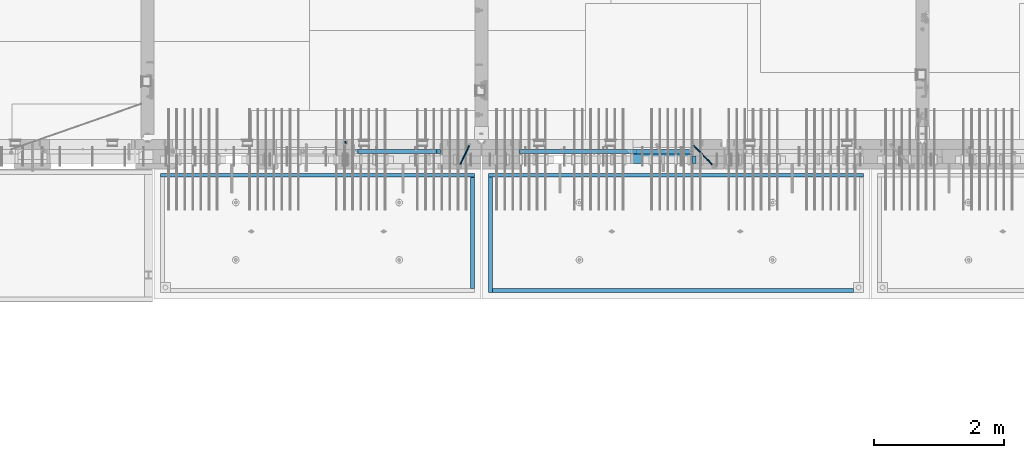
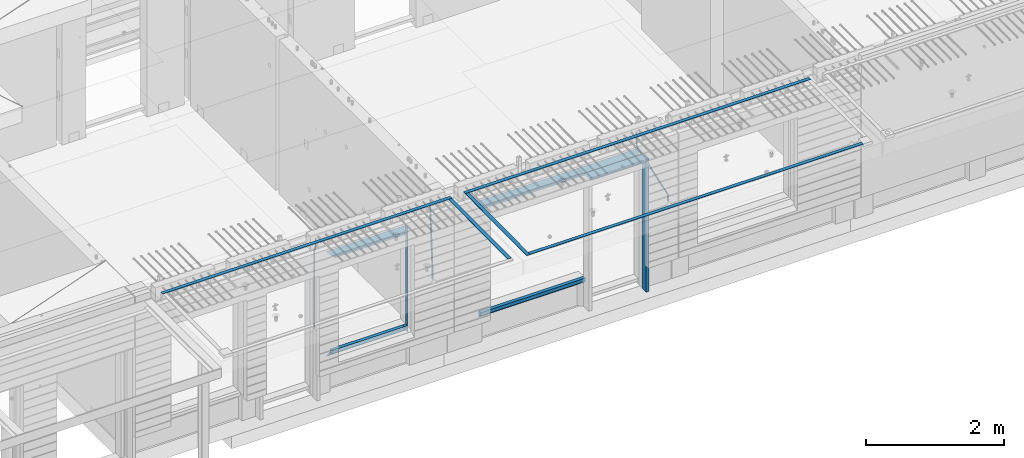
# One storey, part 87 of 325: 21 beams, 4 elements without a shape of their own.
"""IFC2X3 building model written with IfcOpenShell, lengths in millimetres."""

from ifc_helpers import new_model, si_unit, frame, origin_with_axes, place, context, subcontext, project, spatial, faceted_brep, material, type_object, element, aggregate, save


model = new_model("IFC2X3")

# Units and contexts
model_context = context("Model", 3, precision=1e-05, world=origin_with_axes())
body_context = subcontext(model_context, "Body", "Model", "MODEL_VIEW")
ifc_project = project(units=[si_unit("LENGTHUNIT", "METRE", prefix="MILLI"), si_unit("AREAUNIT", "SQUARE_METRE"), si_unit("VOLUMEUNIT", "CUBIC_METRE"), si_unit("MASSUNIT", "GRAM", prefix="KILO"), si_unit("TIMEUNIT", "SECOND"), si_unit("PLANEANGLEUNIT", "RADIAN"), si_unit("SOLIDANGLEUNIT", "STERADIAN"), si_unit("THERMODYNAMICTEMPERATUREUNIT", "DEGREE_CELSIUS"), si_unit("LUMINOUSINTENSITYUNIT", "LUMEN")], contexts=[model_context])

# Site, building, storey
site_placement = place(None, origin_with_axes())
site = spatial("IfcSite", under=ifc_project, at=site_placement, CompositionType="ELEMENT")
building_placement = place(site_placement, origin_with_axes())
building = spatial("IfcBuilding", under=site, at=building_placement, CompositionType="ELEMENT")
storey_placement = place(building_placement, origin_with_axes())
storey = spatial("IfcBuildingStorey", under=building, at=storey_placement, Name="1", CompositionType="ELEMENT", Elevation=0.0)

# Assembly, beams
assembly_1_placement = place(storey_placement, origin_with_axes())
assembly_1 = element("IfcElementAssembly", 1, at=assembly_1_placement, inside=storey, AssemblyPlace="NOTDEFINED", PredefinedType="REINFORCEMENT_UNIT")
ifc_material_1 = material(Name="CONCRETE/C35/45")
beam_type_1 = type_object("IfcBeamType", PredefinedType="NOTDEFINED")
beam_1_placement = place(assembly_1_placement, frame((24034.9998642727, 7815.0, 84140.0), z_axis=(0.0, 0.0, -1.0), x_axis=(1.0, 0.0, 0.0)))
beam_1 = element("IfcBeam", 2, at=beam_1_placement, type_object=beam_type_1, material=ifc_material_1, Name="SK", context=body_context, shape_type="Brep", body=[
    faceted_brep([(70.0000000000164, -35.0, 35.0), (70.0000000000164, 35.0, 35.0), (0.0, -35.0, -35.0), (1039.99961853026, -35.0, -35.0), (980.889062997325, -35.0, 35.0), (980.889062997325, 35.0, 35.0)], [[[0, 1, 2]], [[0, 2, 3, 4]], [[1, 0, 4, 5]], [[2, 1, 5, 3]], [[4, 3, 5]]]),
])
ifc_material_2 = material(Name="TIMBER")
beam_type_2 = type_object("IfcBeamType", Name="50X150", PredefinedType="NOTDEFINED")
beam_2_placement = place(assembly_1_placement, frame((24104.9998642727, 7705.0, 84080.0), z_axis=(0.0, 0.0, -1.0), x_axis=(1.0, 0.0, 0.0)))
beam_2 = element("IfcBeam", 3, at=beam_2_placement, type_object=beam_type_2, material=ifc_material_2, ObjectType="50X150", context=body_context, shape_type="Brep", body=[
    faceted_brep([(50.0000000000036, -75.0, 25.0), (50.0000000000036, 75.0, 25.0), (0.0, 75.0, -25.0), (0.0, -75.0, -25.0), (1009.99961853027, -75.0, -25.0), (959.999618530259, -75.0, 25.0), (959.999618530259, 75.0, 25.0), (1009.99961853027, 75.0, -25.0)], [[[0, 1, 2, 3]], [[0, 3, 4, 5]], [[1, 0, 5, 6]], [[2, 1, 6, 7]], [[3, 2, 7, 4]], [[6, 5, 4, 7]]]),
])

assembly_2_placement = place(storey_placement, origin_with_axes())
assembly_2 = element("IfcElementAssembly", 4, at=assembly_2_placement, inside=storey, AssemblyPlace="NOTDEFINED", PredefinedType="REINFORCEMENT_UNIT")
ifc_material_3 = material()
beam_type_3 = type_object("IfcBeamType", Name="D20", PredefinedType="NOTDEFINED")
beam_3_placement = place(assembly_2_placement, frame((19710.0073333522, 7925.0, 84407.5000058722), z_axis=(0.000415599999849905, 0.999999913638203, 4.76000000899737e-07), x_axis=(0.0, 0.0, -1.0)))
beam_3 = element("IfcBeam", 5, at=beam_3_placement, type_object=beam_type_3, material=ifc_material_3, Name="JM20", ObjectType="D20", context=body_context, shape_type="Brep", body=[
    faceted_brep([(0.0, -10.0, 0.0), (-4.19531716033816e-08, -7.07106781186667, -7.07106781187031), (113.248091332178, -7.0710684840451, -7.0710678117357), (113.248091314759, -10.0000006713562, -2.51020537689328e-10), (0.0, 0.0, -10.0), (113.248091374131, -6.72178430249915e-07, -9.99999999986903), (4.196772351861e-08, 7.07106781186303, -7.07106781186667), (113.248091416113, 7.07106713968824, -7.07106781173934), (0.0, 10.0, 0.0), (113.248091433488, 9.99999932782521, 1.30967237055302e-10), (4.196772351861e-08, 7.07106781185939, 7.07106781185939), (113.248091416113, 7.0710671396846, 7.071067811994), (0.0, 0.0, 10.0), (113.248091374131, -6.72174792271107e-07, 10.0000000001273), (-4.19531716033816e-08, -7.07106781187031, 7.07106781185939), (113.248091332178, -7.0710684840451, 7.071067811994), (130.699843527167, -7.06993249763036, -4.33745683788584), (128.538066582521, -9.99900540317321, 2.39499413731755), (131.594536475241, 0.00119355250353692, -7.12624594330919), (130.698046432328, 7.07220300913468, -4.33773834422391), (128.535525107087, 10.0009944322555, 2.39459602660281), (126.373748162892, 7.07192152754578, 9.1270470011732), (125.479055214906, 0.000795477419160306, 11.9158361066184), (126.37554525779, -7.07021397921199, 9.12732850753673), (240.336258550378, -7.05529970173666, 30.8729495437874), (238.174481606227, -9.98437260450009, 37.6054005176375), (241.230951498423, 0.0158263482953771, 28.0841604381058), (240.334461455612, 7.0868358050102, 30.8726680369582), (238.171940130502, 10.0156272283348, 37.6050024077231), (236.010163186409, 7.08655432384694, 44.3374533824244), (235.115470238379, 0.0154282738185429, 47.1262424881097), (236.011960281176, -7.05558118289991, 44.3377348892536), (253.461915329972, -7.05444528127919, 32.9289287376414), (253.46191532613, -9.98337746617108, 39.9999965521893), (253.461915339081, 0.0166225284556276, 29.9999965443676), (253.461915348205, 7.08769034247234, 32.9289287273205), (253.461915352003, 10.0166225357716, 39.9999965370152), (253.461915348293, 7.08769035281148, 47.0710643509774), (253.461915339183, 0.0166225430875784, 49.999996544273), (253.46191533003, -7.05444527093641, 47.0710643613093), (1617.47998045172, -7.05444857276962, 32.9289287369675), (1617.47998044467, -9.98338075699212, 39.9999965504549), (1617.47998046874, 0.0166192374708771, 29.9999965449206), (1617.47998048575, 7.08768705096008, 32.9289287291404), (1617.47998049279, 10.0166192430079, 39.9999965393854), (1617.47998048575, 7.08768705878902, 47.071064352871), (1617.47998046874, 0.0166192485448846, 49.9999965449197), (1617.47998045172, -7.05444856494069, 47.0710643606981)], [[[0, 1, 2, 3]], [[1, 4, 5, 2]], [[4, 6, 7, 5]], [[6, 8, 9, 7]], [[8, 10, 11, 9]], [[10, 12, 13, 11]], [[12, 14, 15, 13]], [[14, 0, 3, 15]], [[14, 12, 10, 8, 6, 4, 1, 0]], [[3, 2, 16, 17]], [[2, 5, 18, 16]], [[5, 7, 19, 18]], [[7, 9, 20, 19]], [[9, 11, 21, 20]], [[11, 13, 22, 21]], [[13, 15, 23, 22]], [[15, 3, 17, 23]], [[17, 16, 24, 25]], [[16, 18, 26, 24]], [[18, 19, 27, 26]], [[19, 20, 28, 27]], [[20, 21, 29, 28]], [[21, 22, 30, 29]], [[22, 23, 31, 30]], [[23, 17, 25, 31]], [[25, 24, 32, 33]], [[24, 26, 34, 32]], [[26, 27, 35, 34]], [[27, 28, 36, 35]], [[28, 29, 37, 36]], [[29, 30, 38, 37]], [[30, 31, 39, 38]], [[31, 25, 33, 39]], [[33, 32, 40, 41]], [[32, 34, 42, 40]], [[34, 35, 43, 42]], [[35, 36, 44, 43]], [[36, 37, 45, 44]], [[37, 38, 46, 45]], [[38, 39, 47, 46]], [[39, 33, 41, 47]], [[42, 43, 44, 45, 46, 47, 41, 40]]]),
])
beam_4_placement = place(assembly_2_placement, frame((21625.0073331492, 7924.99999997881, 84407.5), z_axis=(-0.000415599999849952, -0.999999913638316, 0.0), x_axis=(-6.05680000062309e-05, -4.00000390151988e-09, -0.999999998165759)))
beam_4 = element("IfcBeam", 6, at=beam_4_placement, type_object=beam_type_3, material=ifc_material_3, Name="JM20", ObjectType="D20", context=body_context, shape_type="Brep", body=[
    faceted_brep([(-0.00060564729210455, -9.99999998165731, 0.0), (-0.000428079845733009, -7.07106779890455, -7.07106781186667), (119.575515501536, -7.07830994756296, -7.07106481604933), (119.575337932896, -10.0072421307195, -3.43332612828817e-06), (0.0, 0.0, -10.0), (119.575943836026, -0.00724214867295814, -9.99999700418266), (0.00042843479604926, 7.07106779888636, -7.07106781186303), (119.57637202373, 7.06382565022977, -7.07106481604933), (0.00060564729210455, 9.99999998166459, 3.63797880709171e-12), (119.576549238118, 9.99275783300072, 2.99581552098971e-06), (0.000428079845733009, 7.07106779890819, 7.07106781186667), (119.576371669405, 7.06382565024978, 7.07107080768037), (0.0, 0.0, 10.0), (119.57594333493, -0.00724214864203532, 10.0000029958155), (-0.000428434810601175, -7.07106779888272, 7.07106781186667), (119.575515147211, -7.07830994754295, 7.07107080768037), (123.006973508192, -7.07825951346604, -6.96785036235087), (122.582196132164, -10.0072047447829, 0.090452766209637), (123.182421564867, -0.00718632049392909, -9.89150999405319), (123.005765870272, 7.06387605862983, -6.9678969281922), (122.5804889344, 9.99279518261392, 0.090375952400791), (122.155712218591, 7.06384995171538, 7.14866812117907), (121.980264161975, -0.00722324126036256, 10.0723277528814), (122.156919856599, -7.07828562038412, 7.14871468701676), (235.904703171851, -7.06860422895625, -0.169508357435916), (235.479926262604, -9.99754169577864, 6.88878701985595), (236.080151695453, 0.002465748351824, -3.09317573838871), (235.903496467319, 7.07353134315781, -0.16957042179456), (235.478219724217, 10.0024582304504, 6.88869924890878), (235.053442814489, 7.07352076285679, 13.9469946275131), (234.877994290917, 0.00245078554871725, 16.8706620084649), (235.05464951905, -7.06861480925727, 13.9470566918726), (247.69730842374, 6.49890140729985, 1.5904257279044), (247.708271375333, -0.564091162203113, -1.35790592567901), (246.351191555892, -7.5775885142175, 1.3894260566567), (244.421027918448, -10.4331790195793, 8.22307186000126), (243.04844414418, -7.45809648886643, 15.1399744532118), (243.037481192529, -0.395103919359826, 18.0883061067871), (244.394561011999, 6.61839343264, 15.3409741244495), (246.324724649443, 9.47398393802723, 8.50732832109588), (256.620302657771, 7.90789673379186, 11.9850227549905), (258.892076862918, 4.79603600307382, 5.371853429986), (253.26121545503, 5.26966351612282, 18.3359992487194), (250.782522980895, -1.57322241172369, 20.7044670154446), (250.636209669712, -8.61229127897968, 17.7030097594688), (252.907983874131, -11.724152010418, 11.0898404357176), (256.267071077629, -9.08591879203959, 4.7388639407518), (258.745763551793, -2.24303286420036, 2.37039617402661), (1008.47908473376, -166.485147783689, 337.205828025195), (1005.11999753102, -169.123381001344, 343.556804518913), (1010.95777720789, -159.642261855857, 334.837360258474), (1011.10409051905, -152.60319298859, 337.838817514449), (1008.83231631388, -149.491332257865, 344.451986839456), (1005.47322911114, -152.129565475519, 350.802963333173), (1002.99453663701, -158.972451403351, 353.171431099895), (1002.84822332587, -166.011520270618, 350.169973843918), (1010.17087503639, -166.839152352099, 337.953575170377), (1008.40147312843, -169.810024819315, 345.007169854448), (1011.47638800017, -159.75078038171, 335.066578819891), (1011.55326023143, -152.697181073247, 338.037344110582), (1010.35646101969, -149.810257238067, 345.125637025791), (1008.58705911171, -152.781129705283, 352.179231709861), (1007.28154614793, -159.869501675676, 355.066228060347), (1007.20467391667, -166.923100984135, 352.095462769656), (1012.05411677422, -166.839038287919, 337.953575122971), (1012.05429688386, -169.809803575103, 345.007169762499), (1012.05368737834, -159.750745415844, 335.066578805359), (1012.05326023052, -152.697150789249, 338.037344097996), (1012.05308554815, -149.81015447692, 345.125636983083), (1012.05326565779, -152.780919764096, 352.179231622609), (1012.05369505366, -159.869212636178, 355.066227940223), (1012.05412220149, -166.92280726277, 352.095462647586), (1117.510115663, -166.832651029355, 337.953572468433), (1117.51029577265, -169.803416316539, 345.00716710796), (1117.50968626713, -159.744358157277, 335.06657615082), (1117.50925911931, -152.690763530685, 338.037341443456), (1117.50908443694, -149.803767218353, 345.125634328543), (1117.50926454658, -152.774532505533, 352.17922896807), (1117.50969394245, -159.862825377615, 355.066225285684), (1117.51012109026, -166.916420004207, 352.095459993046)], [[[0, 1, 2, 3]], [[1, 4, 5, 2]], [[4, 6, 7, 5]], [[6, 8, 9, 7]], [[8, 10, 11, 9]], [[10, 12, 13, 11]], [[12, 14, 15, 13]], [[14, 0, 3, 15]], [[14, 12, 10, 8, 6, 4, 1, 0]], [[3, 2, 16, 17]], [[2, 5, 18, 16]], [[5, 7, 19, 18]], [[7, 9, 20, 19]], [[9, 11, 21, 20]], [[11, 13, 22, 21]], [[13, 15, 23, 22]], [[15, 3, 17, 23]], [[17, 16, 24, 25]], [[16, 18, 26, 24]], [[18, 19, 27, 26]], [[19, 20, 28, 27]], [[20, 21, 29, 28]], [[21, 22, 30, 29]], [[22, 23, 31, 30]], [[23, 17, 25, 31]], [[26, 27, 32, 33]], [[24, 26, 33, 34]], [[25, 24, 34, 35]], [[31, 25, 35, 36]], [[30, 31, 36, 37]], [[29, 30, 37, 38]], [[28, 29, 38, 39]], [[27, 28, 39, 32]], [[39, 40, 41, 32]], [[38, 42, 40, 39]], [[37, 43, 42, 38]], [[36, 44, 43, 37]], [[35, 45, 44, 36]], [[34, 46, 45, 35]], [[33, 47, 46, 34]], [[32, 41, 47, 33]], [[45, 46, 48, 49]], [[46, 47, 50, 48]], [[47, 41, 51, 50]], [[41, 40, 52, 51]], [[40, 42, 53, 52]], [[42, 43, 54, 53]], [[43, 44, 55, 54]], [[44, 45, 49, 55]], [[49, 48, 56, 57]], [[48, 50, 58, 56]], [[50, 51, 59, 58]], [[51, 52, 60, 59]], [[52, 53, 61, 60]], [[53, 54, 62, 61]], [[54, 55, 63, 62]], [[55, 49, 57, 63]], [[57, 56, 64, 65]], [[56, 58, 66, 64]], [[58, 59, 67, 66]], [[59, 60, 68, 67]], [[60, 61, 69, 68]], [[61, 62, 70, 69]], [[62, 63, 71, 70]], [[63, 57, 65, 71]], [[65, 64, 72, 73]], [[64, 66, 74, 72]], [[66, 67, 75, 74]], [[67, 68, 76, 75]], [[68, 69, 77, 76]], [[69, 70, 78, 77]], [[70, 71, 79, 78]], [[71, 65, 73, 79]], [[74, 75, 76, 77, 78, 79, 73, 72]]]),
])

# Beam
beam_5_placement = place(assembly_1_placement, frame((25075.0293329014, 7924.99999993642, 84407.5), z_axis=(-0.000415599999849952, -0.999999913638316, 0.0), x_axis=(-0.000242263999929879, 0.0, -0.999999970654077)))
beam_5 = element("IfcBeam", 7, at=beam_5_placement, type_object=beam_type_3, material=ifc_material_3, Name="JM20", ObjectType="D20", context=body_context, shape_type="Brep", body=[
    faceted_brep([(-0.00060564729210455, -9.99999998165731, 0.0), (-0.000428079845733009, -7.07106779890455, -7.07106781186667), (119.575515501536, -7.07830994756296, -7.07106481604933), (119.575337932896, -10.0072421307195, -3.43332612828817e-06), (0.0, 0.0, -10.0), (119.575943836026, -0.00724214867295814, -9.99999700418266), (0.00042843479604926, 7.07106779888636, -7.07106781186303), (119.57637202373, 7.06382565022977, -7.07106481604933), (0.00060564729210455, 9.99999998166459, 3.63797880709171e-12), (119.576549238118, 9.99275783300072, 2.99581552098971e-06), (0.000428079845733009, 7.07106779890819, 7.07106781186667), (119.576371669405, 7.06382565024978, 7.07107080768037), (0.0, 0.0, 10.0), (119.57594333493, -0.00724214864203532, 10.0000029958155), (-0.000428434810601175, -7.07106779888272, 7.07106781186667), (119.575515147211, -7.07830994754295, 7.07107080768037), (123.008274907785, -7.07795567963694, -6.96780325792497), (122.584029738471, -10.0069316327917, 0.0905081323508057), (123.182440752484, -0.00686994861462153, -9.89150922917906), (123.004503280346, 7.06417944043824, -6.96794247666548), (122.578695849254, 9.99306765562687, 0.0903112464729929), (122.15445067735, 7.0640917031651, 7.14862263591931), (121.980284832651, -0.0069940278553986, 10.072328607177), (122.158222304832, -7.07804341691372, 7.14876185467801), (233.088395941915, -7.04853267872386, -0.33914435535371), (232.664150764584, -9.97750862893736, 6.71916703474017), (233.262561786629, 0.0225530520438042, -3.26285032724809), (233.08462431423, 7.09360244138225, -0.339283575355694), (232.658816882788, 10.0224906572403, 6.71897014756632), (232.234571710651, 7.09351470543697, 13.777281537301), (232.060405865923, 0.0224289746693103, 16.7009875091953), (232.238343338337, -7.04862041468004, 13.7774207573038), (248.070459246126, -5.60737147376494, 1.85103242021069), (247.013897852143, -8.59717146491312, 8.81690765643543), (244.865343898215, -5.8339984379636, 15.6233189364948), (242.883391151001, 1.06351832306973, 18.2831628436061), (242.22904064988, 8.05490704629119, 15.2383388907911), (243.285602043848, 11.0447070374539, 8.27246365456904), (245.434155997835, 8.28153401051895, 1.46605237452331), (247.416108745019, 1.38401724946743, -1.19379153259433), (260.512945877912, 5.37327174938764, 3.16696371259513), (261.933955342625, -1.38459511741894, 6.46705632785779), (256.86166640259, 11.762316953962, 5.27098446848322), (253.118986913221, 14.0399244660766, 11.5466117722399), (251.477318295016, 10.8719026949148, 18.3176682617204), (252.898327759729, 4.11403582813364, 21.6177608769931), (256.54960723508, -2.27500937642981, 19.5137401211105), (260.292286730517, -4.55261688891915, 13.2381128181169), (1011.6899267952, 318.016952836686, 337.688913324002), (1010.04825817693, 314.848931065488, 344.459969813425), (1010.26891733034, 324.774819703332, 334.388820708672), (1006.61763785462, 331.163864907652, 336.492841464405), (1002.87495836492, 333.441472419578, 342.76846876801), (1001.23328974665, 330.273450648383, 349.539525257433), (1002.6542992115, 323.515583781733, 352.839617872763), (1006.30557868723, 317.12653857741, 350.73559711703), (1012.11607330808, 318.198494379605, 337.877173297548), (1011.23010097447, 315.352404773395, 344.982075913254), (1011.34812648257, 325.234570724882, 334.865586047124), (1009.37611333313, 332.338995712049, 337.711461129013), (1007.35521241752, 335.350093536494, 344.747723517063), (1006.46924008391, 332.504003930284, 351.85262613277), (1007.23718690944, 325.467927585003, 354.864213383194), (1009.20920005886, 318.363502597836, 352.018338301305), (1012.61607329341, 318.198615511596, 337.877173247205), (1012.61676345688, 315.352740711776, 344.982075773638), (1012.61436835937, 325.234877489685, 334.865585919631), (1012.61264738202, 332.339779807688, 337.71146080314), (1012.61191848651, 335.351367047057, 344.747722987787), (1012.61260864999, 332.505492247237, 351.852625514221), (1012.61431358402, 325.469230269144, 354.864212841793), (1012.61603456138, 318.364327951142, 352.018337958285), (1117.42297412557, 318.224006449098, 337.87716269464), (1117.42366428903, 315.378131649279, 344.982065221072), (1117.42126919153, 325.260268427191, 334.865575367066), (1117.41954821418, 332.365170745194, 337.711450250575), (1117.41881931867, 335.376757984559, 344.747712435222), (1117.41950948215, 332.530883184736, 351.852614961655), (1117.42121441617, 325.494621206646, 354.864202289227), (1117.42293539354, 318.389718888644, 352.018327405719)], [[[0, 1, 2, 3]], [[1, 4, 5, 2]], [[4, 6, 7, 5]], [[6, 8, 9, 7]], [[8, 10, 11, 9]], [[10, 12, 13, 11]], [[12, 14, 15, 13]], [[14, 0, 3, 15]], [[14, 12, 10, 8, 6, 4, 1, 0]], [[3, 2, 16, 17]], [[2, 5, 18, 16]], [[5, 7, 19, 18]], [[7, 9, 20, 19]], [[9, 11, 21, 20]], [[11, 13, 22, 21]], [[13, 15, 23, 22]], [[15, 3, 17, 23]], [[17, 16, 24, 25]], [[16, 18, 26, 24]], [[18, 19, 27, 26]], [[19, 20, 28, 27]], [[20, 21, 29, 28]], [[21, 22, 30, 29]], [[22, 23, 31, 30]], [[23, 17, 25, 31]], [[25, 24, 32, 33]], [[31, 25, 33, 34]], [[30, 31, 34, 35]], [[29, 30, 35, 36]], [[28, 29, 36, 37]], [[27, 28, 37, 38]], [[26, 27, 38, 39]], [[24, 26, 39, 32]], [[39, 40, 41, 32]], [[38, 42, 40, 39]], [[37, 43, 42, 38]], [[36, 44, 43, 37]], [[35, 45, 44, 36]], [[34, 46, 45, 35]], [[33, 47, 46, 34]], [[32, 41, 47, 33]], [[47, 41, 48, 49]], [[41, 40, 50, 48]], [[40, 42, 51, 50]], [[42, 43, 52, 51]], [[43, 44, 53, 52]], [[44, 45, 54, 53]], [[45, 46, 55, 54]], [[46, 47, 49, 55]], [[49, 48, 56, 57]], [[48, 50, 58, 56]], [[50, 51, 59, 58]], [[51, 52, 60, 59]], [[52, 53, 61, 60]], [[53, 54, 62, 61]], [[54, 55, 63, 62]], [[55, 49, 57, 63]], [[57, 56, 64, 65]], [[56, 58, 66, 64]], [[58, 59, 67, 66]], [[59, 60, 68, 67]], [[60, 61, 69, 68]], [[61, 62, 70, 69]], [[62, 63, 71, 70]], [[63, 57, 65, 71]], [[65, 64, 72, 73]], [[64, 66, 74, 72]], [[66, 67, 75, 74]], [[67, 68, 76, 75]], [[68, 69, 77, 76]], [[69, 70, 78, 77]], [[70, 71, 79, 78]], [[71, 65, 73, 79]], [[74, 75, 76, 77, 78, 79, 73, 72]]]),
])

# Assembly, beams
assembly_3_placement = place(storey_placement, origin_with_axes())
assembly_3 = element("IfcElementAssembly", 8, at=assembly_3_placement, inside=storey, AssemblyPlace="NOTDEFINED", PredefinedType="REINFORCEMENT_UNIT")
ifc_material_4 = material(Name="CONCRETE/Concrete_Undefined")
beam_type_4 = type_object("IfcBeamType", PredefinedType="NOTDEFINED")
beam_6_placement = place(assembly_3_placement, frame((21949.9413897781, 7420.05314849477, 84725.6636561746), z_axis=(2.93000000986506e-07, -0.00901322400064496, 0.999959380071525), x_axis=(3.25389999851993e-05, -0.999959379542196, -0.00901322399586982)))
beam_6 = element("IfcBeam", 9, at=beam_6_placement, type_object=beam_type_4, material=ifc_material_4, context=body_context, shape_type="Brep", body=[
    faceted_brep([(2.5465851649642e-11, 29.9999999999982, -4.99999999998545), (-2.91038304567337e-11, 29.9999999999982, 5.0), (1775.16788460852, 30.0000000000036, 5.0), (1775.16788460861, 30.0000000000036, -4.99999999998545), (-2.5465851649642e-11, -30.0000000000018, 5.0), (1775.16788460852, -29.9999999999927, 5.0), (2.72848410531878e-11, -30.0000000000018, -4.99999999998545), (1775.16788460861, -29.9999999999927, -4.99999999998545)], [[[0, 1, 2, 3]], [[1, 4, 5, 2]], [[4, 6, 7, 5]], [[6, 0, 3, 7]], [[5, 7, 3, 2]], [[6, 4, 1, 0]]]),
])
beam_7_placement = place(assembly_3_placement, frame((27700.0033616247, 7449.93184428144, 84725.2788442816), z_axis=(6.6541999986247e-05, -1.00000033832184e-09, 0.999999997786081), x_axis=(-0.999999997707994, 1.24969999963762e-05, 6.65419999798477e-05)))
beam_7 = element("IfcBeam", 10, at=beam_7_placement, type_object=beam_type_4, material=ifc_material_4, context=body_context, shape_type="Brep", body=[
    faceted_brep([(2.5465851649642e-11, 29.9999999999982, -4.99999999998545), (-2.91038304567337e-11, 29.9999999999982, 5.0), (5780.0600107005, 30.0, 5.00000000001455), (5780.0600107005, 30.0000000000009, -5.0), (-2.5465851649642e-11, -30.0000000000018, 5.0), (5780.0600107005, -30.0000000000009, 5.00000000001455), (2.72848410531878e-11, -30.0000000000018, -4.99999999998545), (5780.0600107005, -30.0, -4.99999999998545)], [[[0, 1, 2, 3]], [[1, 4, 5, 2]], [[4, 6, 7, 5]], [[6, 0, 3, 7]], [[5, 7, 3, 2]], [[6, 4, 1, 0]]]),
])
beam_8_placement = place(assembly_3_placement, frame((21979.9397016438, 5674.8679591, 84709.8457712343), z_axis=(0.000327872000083623, 1.99999976807677e-09, 0.999999946249974), x_axis=(0.999999946233322, 5.77100000136594e-06, -0.000327872000077393)))
beam_8 = element("IfcBeam", 11, at=beam_8_placement, type_object=beam_type_4, material=ifc_material_4, context=body_context, shape_type="Brep", body=[
    faceted_brep([(2.5465851649642e-11, 29.9999999999982, -4.99999999998545), (-2.91038304567337e-11, 29.9999999999982, 5.0), (5570.052902922, 30.0000000000009, 5.00000000001455), (5570.05290292199, 30.0000000000009, -4.99999999998545), (-2.5465851649642e-11, -30.0000000000018, 5.0), (5570.052902922, -30.0, 5.00000000001455), (2.72848410531878e-11, -30.0000000000018, -4.99999999998545), (5570.05290292199, -30.0, -4.99999999998545)], [[[0, 1, 2, 3]], [[1, 4, 5, 2]], [[4, 6, 7, 5]], [[6, 0, 3, 7]], [[5, 7, 3, 2]], [[6, 4, 1, 0]]]),
])
aggregate(assembly_3, [beam_6, beam_7, beam_8])

assembly_4_placement = place(storey_placement, origin_with_axes())
assembly_4 = element("IfcElementAssembly", 12, at=assembly_4_placement, inside=storey, AssemblyPlace="NOTDEFINED", PredefinedType="REINFORCEMENT_UNIT")
beam_9_placement = place(assembly_4_placement, frame((21670.0013901233, 7419.93998011425, 84723.2790373903), z_axis=(-5.99999839176643e-09, -0.0089070149978186, 0.99996033175513), x_axis=(-7.26999998800451e-07, -0.999960331754865, -0.00890701499781462)))
beam_9 = element("IfcBeam", 13, at=beam_9_placement, type_object=beam_type_4, material=ifc_material_4, context=body_context, shape_type="Brep", body=[
    faceted_brep([(2.5465851649642e-11, 29.9999999999982, -4.99999999998545), (-2.91038304567337e-11, 29.9999999999982, 5.0), (1714.98205429674, 30.0, 5.00000000001455), (1714.98205429674, 30.0000000000036, -4.99999999998545), (-2.5465851649642e-11, -30.0000000000018, 5.0), (1714.98205429674, -30.0, 5.00000000001455), (2.72848410531878e-11, -30.0000000000018, -4.99999999998545), (1714.98205429674, -29.9999999999964, -4.99999999998545)], [[[0, 1, 2, 3]], [[1, 4, 5, 2]], [[4, 6, 7, 5]], [[6, 0, 3, 7]], [[5, 7, 3, 2]], [[6, 4, 1, 0]]]),
])
beam_10_placement = place(assembly_4_placement, frame((21700.0027302922, 7449.93184428734, 84723.6588442717), z_axis=(0.0, 0.0, 1.0), x_axis=(-0.999999999888168, 1.49249999983396e-05, 9.53000001204034e-07)))
beam_10 = element("IfcBeam", 14, at=beam_10_placement, type_object=beam_type_4, material=ifc_material_4, context=body_context, shape_type="Brep", body=[
    faceted_brep([(2.5465851649642e-11, 29.9999999999982, -4.99999999998545), (-2.91038304567337e-11, 29.9999999999982, 5.0), (4840.00999799337, 29.9999999999991, 5.0), (4840.00999799337, 29.9999999999982, -5.00000000001455), (-2.5465851649642e-11, -30.0000000000018, 5.0), (4840.00999799337, -30.0000000000009, 5.0), (2.72848410531878e-11, -30.0000000000018, -4.99999999998545), (4840.00999799337, -30.0000000000009, -5.0)], [[[0, 1, 2, 3]], [[1, 4, 5, 2]], [[4, 6, 7, 5]], [[6, 0, 3, 7]], [[5, 7, 3, 2]], [[6, 4, 1, 0]]]),
])
aggregate(assembly_4, [beam_9, beam_10])

# Beam
beam_type_5 = type_object("IfcBeamType", PredefinedType="NOTDEFINED")
beam_11_placement = place(assembly_2_placement, frame((19845.0006272121, 7820.0, 84145.0), z_axis=(0.0, 0.0, -1.0), x_axis=(1.0, 0.0, 0.0)))
beam_11 = element("IfcBeam", 15, at=beam_11_placement, type_object=beam_type_5, material=ifc_material_1, Name="SK", context=body_context, shape_type="Brep", body=[
    faceted_brep([(0.0, -30.0, -30.0), (49.817662327685, -30.0, 30.0), (49.817662327685, 30.0, 30.0), (1329.99923706055, -30.0, -30.0), (1280.18157473286, -30.0, 30.0), (1280.18157473286, 30.0, 30.0)], [[[0, 1, 2]], [[1, 0, 3, 4]], [[2, 1, 4, 5]], [[0, 2, 5, 3]], [[4, 3, 5]]]),
])

beam_12_placement = place(assembly_2_placement, frame((19905.0006272121, 7820.0, 84085.0), z_axis=(0.0, 0.0, -1.0), x_axis=(1.0, 0.0, 0.0)))
beam_12 = element("IfcBeam", 16, at=beam_12_placement, type_object=beam_type_5, material=ifc_material_1, Name="SK", context=body_context, shape_type="Brep", body=[
    faceted_brep([(0.0, -30.0, -30.0), (53.0959879499314, -30.0, 24.0540540540678), (54.6888675884184, 30.0, 25.6756756756804), (0.0, 30.0, -30.0), (1269.99923706055, -30.0, -30.0), (1211.91971158142, -30.0, 24.0540540540533), (1210.17732581704, 30.0, 25.6756756756804), (1269.99923706055, 30.0, -30.0)], [[[0, 1, 2, 3]], [[1, 0, 4, 5]], [[2, 1, 5, 6]], [[3, 2, 6, 7]], [[0, 3, 7, 4]], [[6, 5, 4, 7]]]),
])

beam_13_placement = place(assembly_2_placement, frame((21144.9998642727, 7820.0, 84175.0), z_axis=(-1.0, 3.00000001838171e-08, 0.0), x_axis=(0.0, 0.0, -1.0)))
beam_13 = element("IfcBeam", 17, at=beam_13_placement, type_object=beam_type_5, material=ifc_material_1, Name="SK", context=body_context, shape_type="Brep", body=[
    faceted_brep([(1740.94594594595, -30.0, 30.0), (1739.32432432432, 30.0, 30.0), (1739.32432432432, 30.0, -24.3243243243269), (1740.94594594595, -30.0, -25.9459459459504), (115.67567567568, 30.0, -24.3243243243269), (114.054054054053, -30.0, -25.9459459459504), (115.67567567568, 30.0, 30.0), (114.054054054053, -30.0, 30.0), (72.2635272671032, 30.0, 30.0), (72.2635272671032, -30.0, 30.0), (0.0, 30.0, -30.0), (0.0, -30.0, -30.0), (1855.0, -30.0, -30.0), (1782.73647273288, -30.0, 30.0), (1782.73647273287, 30.0, 30.0), (1855.0, 30.0, -30.0)], [[[0, 1, 2, 3]], [[3, 2, 4, 5]], [[5, 4, 6, 7]], [[7, 6, 8, 9]], [[10, 11, 9, 8]], [[0, 3, 5, 7, 9, 11, 12, 13]], [[1, 0, 13, 14]], [[10, 8, 6, 4, 2, 1, 14, 15]], [[15, 12, 11, 10]], [[15, 14, 13, 12]]]),
])

beam_14_placement = place(assembly_2_placement, frame((21174.9998642727, 7820.0, 82350.0), z_axis=(0.0, 0.0, 1.0), x_axis=(-1.0, 3.00000001838171e-08, 0.0)))
beam_14 = element("IfcBeam", 18, at=beam_14_placement, type_object=beam_type_5, material=ifc_material_1, Name="SK", context=body_context, shape_type="Brep", body=[
    faceted_brep([(1280.18157473286, -30.0, 30.0), (1329.99923706055, -30.0, -30.0), (1280.18157473286, 30.0, 30.0), (0.0, -30.0, -30.0), (49.817662327685, 30.0, 30.0), (49.817662327685, -30.0, 30.0)], [[[0, 1, 2]], [[3, 4, 2, 1]], [[4, 5, 0, 2]], [[5, 3, 1, 0]], [[3, 5, 4]]]),
])

beam_15_placement = place(assembly_2_placement, frame((21174.9998642727, 7820.0, 82410.0), z_axis=(0.0, 0.0, 1.0), x_axis=(-1.0, 3.00000001838171e-08, 0.0)))
beam_15 = element("IfcBeam", 19, at=beam_15_placement, type_object=beam_type_5, material=ifc_material_1, Name="SK", context=body_context, shape_type="Brep", body=[
    faceted_brep([(1269.99923706055, -30.0, -30.0), (1269.99923706055, 30.0, -30.0), (1269.99923706055, 30.0, 25.6756756756804), (1269.99923706055, -30.0, 24.0540540540678), (0.0, -30.0, -30.0), (0.0, 30.0, -30.0), (59.8219112435072, 30.0, 25.6756756756804), (58.0795254791192, -30.0, 24.0540540540533)], [[[0, 1, 2, 3]], [[4, 5, 1, 0]], [[2, 1, 5, 6]], [[3, 2, 6, 7]], [[0, 3, 7, 4]], [[6, 5, 4, 7]]]),
])

beam_16_placement = place(assembly_1_placement, frame((22384.9998642751, 7820.0, 84145.0), z_axis=(0.0, 0.0, -1.0), x_axis=(1.0, 0.0, 0.0)))
beam_16 = element("IfcBeam", 20, at=beam_16_placement, type_object=beam_type_5, material=ifc_material_1, Name="SK", context=body_context, shape_type="Brep", body=[
    faceted_brep([(1820.00000000026, -30.0, 30.0), (1820.00000000026, -30.0, -30.0), (1820.00000000026, 30.0, 30.0), (0.0, -30.0, 30.0), (-5.28234522789717e-09, 30.0, 30.0), (0.0, -30.0, -30.0)], [[[0, 1, 2]], [[3, 0, 2, 4]], [[3, 4, 5]], [[0, 3, 5, 1]], [[4, 2, 1, 5]]]),
])

beam_17_placement = place(assembly_1_placement, frame((22384.9998642751, 7820.0, 84085.0), z_axis=(0.0, 0.0, -1.0), x_axis=(1.0, 0.0, 0.0)))
beam_17 = element("IfcBeam", 21, at=beam_17_placement, type_object=beam_type_5, material=ifc_material_1, Name="SK", context=body_context, shape_type="Brep", body=[
    faceted_brep([(0.0, -30.0, -30.0), (0.0, -30.0, 30.0), (-5.28234522789717e-09, 30.0, 30.0), (0.0, 30.0, -30.0), (1820.00000000026, 30.0, -30.0), (1820.00000000026, -30.0, -30.0), (1820.00000000026, 30.0, 25.6756756756804), (1820.00000000026, -30.0, 24.0540540540678), (4.05405405405327, -30.0, 30.0), (4.05405405404963, -30.0, 24.0540540540533), (5.67567567567312, 30.0, 30.0), (5.67567567567312, 30.0, 25.6756756756804)], [[[0, 1, 2, 3]], [[0, 3, 4, 5]], [[5, 4, 6, 7]], [[8, 1, 0, 5, 7, 9]], [[2, 1, 8, 10]], [[4, 3, 2, 10, 11, 6]], [[7, 6, 11, 9]], [[8, 9, 11, 10]]]),
])

beam_18_placement = place(assembly_1_placement, frame((24144.9998642753, 7820.0, 82150.0), z_axis=(0.0, 0.0, 1.0), x_axis=(-1.0, 3.00000001838171e-08, 0.0)))
beam_18 = element("IfcBeam", 22, at=beam_18_placement, type_object=beam_type_5, material=ifc_material_1, Name="SK", context=body_context, shape_type="Brep", body=[
    faceted_brep([(1760.00000000026, -30.0, 30.0), (0.0, -30.0, 30.0), (0.0, -30.0, -30.0), (1760.00000000026, -30.0, -30.0), (1760.00000000026, 30.0, 30.0), (-5.28234522789717e-09, 30.0, 30.0)], [[[0, 1, 2, 3]], [[0, 3, 4]], [[1, 0, 4, 5]], [[1, 5, 2]], [[4, 3, 2, 5]]]),
])

beam_19_placement = place(assembly_1_placement, frame((24144.9998642753, 7820.0, 82210.0), z_axis=(0.0, 0.0, 1.0), x_axis=(-1.0, 3.00000001838171e-08, 0.0)))
beam_19 = element("IfcBeam", 23, at=beam_19_placement, type_object=beam_type_5, material=ifc_material_1, Name="SK", context=body_context, shape_type="Brep", body=[
    faceted_brep([(1760.00000000026, -30.0, 30.0), (1760.00000000026, 30.0, 30.0), (1754.32432432432, 30.0, 30.0), (1755.94594594594, -30.0, 30.0), (1760.00000000026, -30.0, -30.0), (1760.00000000026, 30.0, -30.0), (0.0, -30.0, -30.0), (0.0, 30.0, -30.0), (0.0, -30.0, 24.0540540540678), (0.0, 30.0, 25.6756756756804), (1754.32432432432, 30.0, 25.6756756756804), (1755.94594594595, -30.0, 24.0540540540533)], [[[0, 1, 2, 3]], [[0, 4, 5, 1]], [[6, 7, 5, 4]], [[7, 6, 8, 9]], [[2, 1, 5, 7, 9, 10]], [[8, 11, 10, 9]], [[6, 4, 0, 3, 11, 8]], [[2, 10, 11, 3]]]),
])

ifc_material_5 = material(Name="CONCRETE/C40/50")
beam_type_6 = type_object("IfcBeamType", PredefinedType="NOTDEFINED")
beam_20_placement = place(assembly_2_placement, frame((21139.9998642727, 7820.0, 84115.0), z_axis=(-1.0, 3.00000001838171e-08, 0.0), x_axis=(0.0, 0.0, -1.0)))
beam_20 = element("IfcBeam", 24, at=beam_20_placement, type_object=beam_type_6, material=ifc_material_5, Name="SK", context=body_context, shape_type="Brep", body=[
    faceted_brep([(1680.94594594595, -30.0, -30.9459459459504), (1679.32432432432, 30.0, -29.3243243243269), (55.6756756756804, 30.0, -29.3243243243269), (54.0540540540533, -30.0, -30.9459459459504), (55.6756756756804, 30.0, 24.8219112435145), (54.0540540540533, -30.0, 23.0795254791374), (0.0, 30.0, -35.0), (0.0, -30.0, -35.0), (1735.0, -30.0, -35.0), (1680.94594594595, -30.0, 23.0795254791337), (1679.32432432432, 30.0, 24.8219112435145), (1735.0, 30.0, -35.0)], [[[0, 1, 2, 3]], [[3, 2, 4, 5]], [[4, 6, 7, 5]], [[0, 3, 5, 7, 8, 9]], [[1, 0, 9, 10]], [[6, 4, 2, 1, 10, 11]], [[11, 8, 7, 6]], [[10, 9, 8, 11]]]),
])

aggregate(assembly_2, [beam_3, beam_4, beam_11, beam_12, beam_13, beam_20, beam_14, beam_15])

beam_type_7 = type_object("IfcBeamType", Name="50X120", PredefinedType="NOTDEFINED")
beam_21_placement = place(assembly_1_placement, frame((25089.9994828029, 7690.0, 84105.0), z_axis=(-1.0, 3.00000001838171e-08, 0.0), x_axis=(0.0, 0.0, -1.0)))
beam_21 = element("IfcBeam", 25, at=beam_21_placement, type_object=beam_type_7, material=ifc_material_2, ObjectType="50X120", context=body_context, shape_type="Brep", body=[
    faceted_brep([(2345.0, -60.0, 25.0), (2345.0, -60.0, -25.0), (2345.0, 60.0, -25.0), (2345.0, 60.0, 25.0), (0.0, -60.0, -25.0), (0.0, 60.0, -25.0), (50.0000000000036, 60.0, 25.0), (50.0000000000036, -60.0, 25.0)], [[[0, 1, 2, 3]], [[4, 5, 2, 1]], [[3, 2, 5, 6]], [[0, 3, 6, 7]], [[1, 0, 7, 4]], [[5, 4, 7, 6]]]),
])

aggregate(assembly_1, [beam_5, beam_16, beam_17, beam_18, beam_19, beam_1, beam_2, beam_21])

save(model, "model.ifc")
